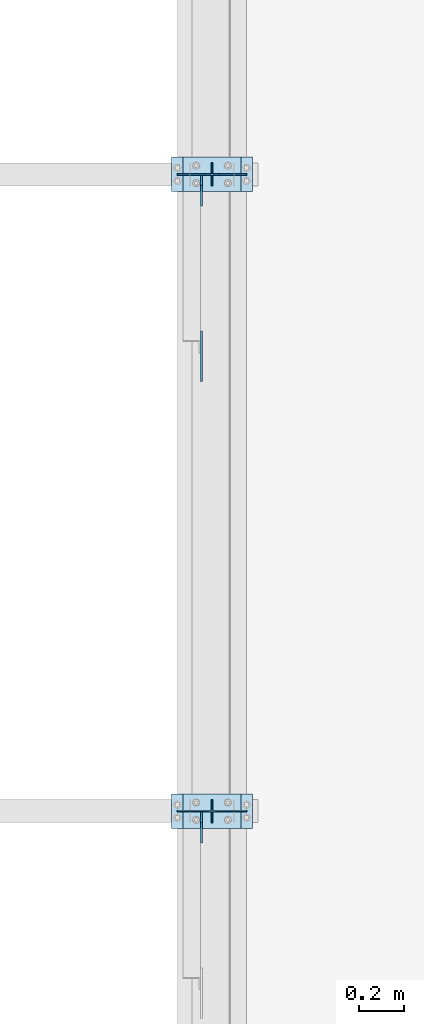
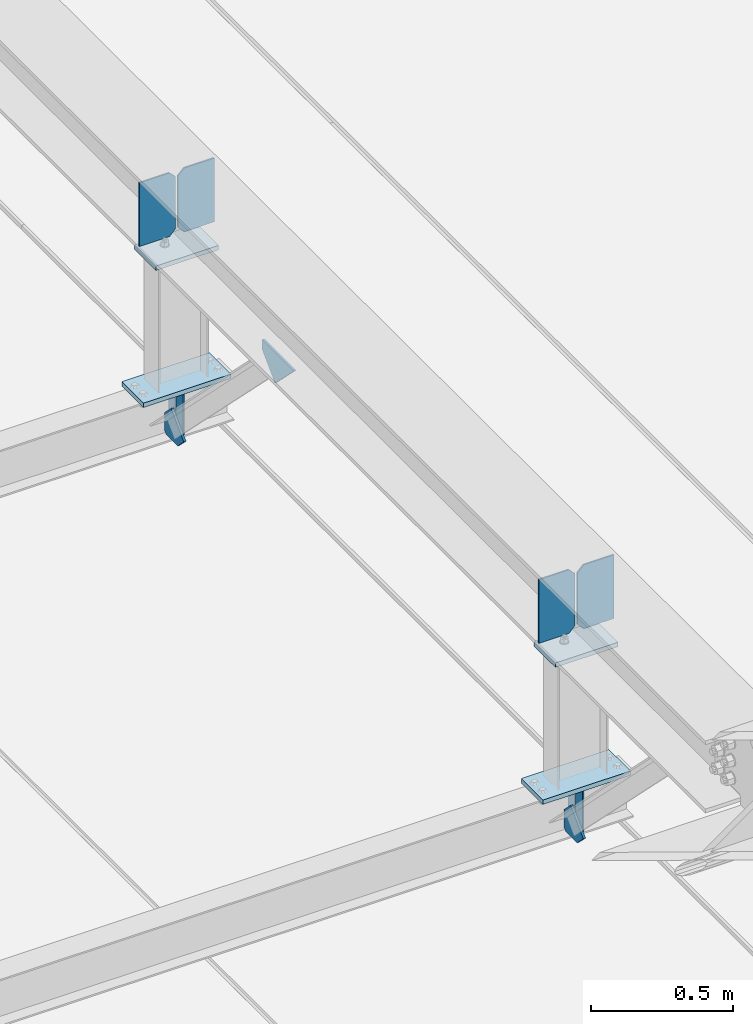
# One storey, part 3288 of 3843: 15 plates, 5 elements without a shape of their own.
"""IFC2X3 building model written with IfcOpenShell, lengths in millimetres."""

import ifcopenshell
import ifcopenshell.guid

model = None  # the IFC model being written
_history = None  # IfcOwnerHistory: only IFC2X3 demands one
_inside = {}  # id of a spatial element -> (the spatial element, [elements in it])
_under = {}  # id of a project, library or spatial element -> (it, [spatial elements below it])
_declared = {}  # id of a project -> (the project, [libraries it declares])
_typed = {}  # id of a type object -> (the type object, [elements of that type])
_made_of = {}  # id of a material, layer set ... -> (it, [elements and type objects made of it])


def new_model(schema):
    """Start an empty IFC model of exactly this schema.

    Asked for "IFC4X3", IfcOpenShell would pick the latest addendum, in which some entities
    have other attributes; the version numbers below select the first issue.
    IFC2X3 requires an IfcOwnerHistory on every rooted entity: one is made here for all.
    """
    global model, _history
    if schema == "IFC4X3":
        model = ifcopenshell.file(schema_version=(4, 3, 0, 0))
    else:
        model = ifcopenshell.file(schema=schema)
    _inside.clear()
    _under.clear()
    _declared.clear()
    _typed.clear()
    _made_of.clear()
    _history = None
    if model.schema == "IFC2X3":
        org = make("IfcOrganization", Name="unknown")
        user = make(
            "IfcPersonAndOrganization",
            ThePerson=make("IfcPerson", FamilyName="unknown"),
            TheOrganization=org,
        )
        app = make(
            "IfcApplication",
            ApplicationDeveloper=org,
            Version="unknown",
            ApplicationFullName="unknown",
            ApplicationIdentifier="unknown",
        )
        _history = make(
            "IfcOwnerHistory",
            OwningUser=user,
            OwningApplication=app,
            ChangeAction="ADDED",
            CreationDate=0,
        )
    return model


def make(cls, **values):
    """One entity of the class cls with the attributes given. An attribute that is None is left unset."""
    return model.create_entity(
        cls, **{name: value for name, value in values.items() if value is not None}
    )


def rooted(cls, **values):
    """An entity with a GlobalId (a new one), such as an element, a storey or a relation."""
    return make(cls, GlobalId=ifcopenshell.guid.new(), OwnerHistory=_history, **values)


def si_unit(unit_type, name, prefix=None):
    """IfcSIUnit, for example si_unit("LENGTHUNIT", "METRE", prefix="MILLI")."""
    return make("IfcSIUnit", UnitType=unit_type, Prefix=prefix, Name=name)


def assignment(units):
    """IfcUnitAssignment: the units of a project."""
    return None if units is None else make("IfcUnitAssignment", Units=units)


def point(xyz):
    """IfcCartesianPoint."""
    return None if xyz is None else make("IfcCartesianPoint", Coordinates=xyz)


def direction(xyz):
    """IfcDirection."""
    return None if xyz is None else make("IfcDirection", DirectionRatios=xyz)


def frame(location, z_axis=None, x_axis=None):
    """IfcAxis2Placement3D, a coordinate frame: its origin and axes. An axis left out is left unset."""
    return make(
        "IfcAxis2Placement3D",
        Location=point(location),
        Axis=direction(z_axis),
        RefDirection=direction(x_axis),
    )


def origin_with_axes():
    """The frame at (0, 0, 0) with the z axis (0, 0, 1) and the x axis (1, 0, 0) written out."""
    return frame((0.0, 0.0, 0.0), z_axis=(0.0, 0.0, 1.0), x_axis=(1.0, 0.0, 0.0))


def place(relative_to, where):
    """IfcLocalPlacement: puts the frame where relative to a parent placement (None: the world)."""
    return make(
        "IfcLocalPlacement", PlacementRelTo=relative_to, RelativePlacement=where
    )


def context(
    kind, dimensions, precision=None, world=None, true_north=None, identifier=None
):
    """IfcGeometricRepresentationContext, for example the 3D "Model" context."""
    return make(
        "IfcGeometricRepresentationContext",
        ContextIdentifier=identifier,
        ContextType=kind,
        CoordinateSpaceDimension=dimensions,
        Precision=precision,
        WorldCoordinateSystem=world,
        TrueNorth=true_north,
    )


def subcontext(parent, identifier, kind, view, scale=None):
    """IfcGeometricRepresentationSubContext, for example "Body" below "Model"."""
    return make(
        "IfcGeometricRepresentationSubContext",
        ContextIdentifier=identifier,
        ContextType=kind,
        ParentContext=parent,
        TargetScale=scale,
        TargetView=view,
    )


def project(units=None, contexts=None):
    """IfcProject with its units and contexts."""
    return rooted(
        "IfcProject",
        Name="project",
        RepresentationContexts=contexts,
        UnitsInContext=assignment(units),
    )


def spatial(cls, under=None, at=None, **own):
    """A site, building, storey or space (cls), placed at a placement, below another one or the project."""
    s = rooted(cls, ObjectPlacement=at, **own)
    if under is not None:
        _under.setdefault(under.id(), (under, []))[1].append(s)
    return s


def faces_of(points, faces, orient=None, outer=None):
    """IfcFace entities. A face is a list of loops; a loop is a list of indices into points, from 0.

    orient and outer hold one flag for each loop. By default every Orientation is true, the
    first loop of a face is its IfcFaceOuterBound and the others are IfcFaceBound.
    """
    made = []
    for i, loops in enumerate(faces):
        bounds = []
        for j, loop in enumerate(loops):
            is_outer = j == 0 if outer is None else outer[i][j]
            bounds.append(
                make(
                    "IfcFaceOuterBound" if is_outer else "IfcFaceBound",
                    Bound=make("IfcPolyLoop", Polygon=[points[k] for k in loop]),
                    Orientation=True if orient is None else orient[i][j],
                )
            )
        made.append(make("IfcFace", Bounds=bounds))
    return made


def faceted_brep(points, faces, orient=None, outer=None, voids=None):
    """IfcFacetedBrep: a solid bounded by flat faces; with voids (closed shells), ...WithVoids."""
    shared = [point(p) for p in points]
    hull = make("IfcClosedShell", CfsFaces=faces_of(shared, faces, orient, outer))
    if voids is None:
        return make("IfcFacetedBrep", Outer=hull)
    return make(
        "IfcFacetedBrepWithVoids",
        Outer=hull,
        Voids=[
            make(cls, CfsFaces=faces_of(shared, fs, o, b)) for cls, fs, o, b in voids
        ],
    )


def shape(context_of_items, identifier, shape_type, items):
    """IfcShapeRepresentation: the items that make up one representation, for example the "Body"."""
    return make(
        "IfcShapeRepresentation",
        ContextOfItems=context_of_items,
        RepresentationIdentifier=identifier,
        RepresentationType=shape_type,
        Items=items,
    )


def material(Name=None, Category=None):
    """IfcMaterial."""
    return make("IfcMaterial", Name=Name, Category=Category)


def made_of(thing, what):
    """Note that an element or type object is made of a material, layer set ...; save() writes the relation."""
    if what is not None:
        _made_of.setdefault(what.id(), (what, []))[1].append(thing)
    return thing


def type_object(cls, material=None, **own):
    """A type object (cls), such as IfcWallType, which elements share."""
    return made_of(rooted(cls, **own), material)


def element(
    cls,
    number,
    at=None,
    inside=None,
    cuts=None,
    type_object=None,
    material=None,
    context=None,
    identifier="Body",
    shape_type=None,
    held_by="IfcProductDefinitionShape",
    body=None,
    shapes=None,
    **own,
):
    """One element of the class cls, such as IfcWall. Its Tag is "e" and its number.

    at: its placement. inside: the storey or other place that contains it. cuts: it is an
    opening in that element (IfcRelVoidsElement). A single representation is given by context,
    identifier, shape_type and body (its items); several are given by shapes. held_by: the class
    of the entity that holds the representations. save() writes the other relations.
    """
    e = rooted(cls, Tag="e%d" % number, ObjectPlacement=at, **own)
    if body is not None:
        shapes = [shape(context, identifier, shape_type, body)]
    if shapes is not None:
        e.Representation = make(held_by, Representations=shapes)
    if inside is not None:
        _inside.setdefault(inside.id(), (inside, []))[1].append(e)
    if cuts is not None:
        rooted(
            "IfcRelVoidsElement", RelatingBuildingElement=cuts, RelatedOpeningElement=e
        )
    if type_object is not None:
        _typed.setdefault(type_object.id(), (type_object, []))[1].append(e)
    return made_of(e, material)


def aggregate(whole, parts):
    """IfcRelAggregates: a whole, such as a stair, and the parts it consists of."""
    return rooted("IfcRelAggregates", RelatingObject=whole, RelatedObjects=parts)


def save(model, path):
    """Write the relations noted so far, then the file.

    IfcRelAggregates (storeys below a building ...), IfcRelContainedInSpatialStructure (elements
    in a storey), IfcRelDefinesByType, IfcRelAssociatesMaterial and IfcRelDeclares: one each for
    every whole, place, type object, material and project.
    """
    for whole, parts in _under.values():
        aggregate(whole, parts)
    for where, things in _inside.values():
        rooted(
            "IfcRelContainedInSpatialStructure",
            RelatedElements=things,
            RelatingStructure=where,
        )
    for kind, things in _typed.values():
        rooted("IfcRelDefinesByType", RelatedObjects=things, RelatingType=kind)
    for what, things in _made_of.values():
        rooted("IfcRelAssociatesMaterial", RelatedObjects=things, RelatingMaterial=what)
    for by, libraries in _declared.values():
        rooted("IfcRelDeclares", RelatingContext=by, RelatedDefinitions=libraries)
    model.write(path)


model = new_model("IFC2X3")

# Units and contexts
model_context = context("Model", 3, precision=1e-05, world=origin_with_axes())
body_context = subcontext(model_context, "Body", "Model", "MODEL_VIEW")
ifc_project = project(units=[si_unit("LENGTHUNIT", "METRE", prefix="MILLI"), si_unit("AREAUNIT", "SQUARE_METRE"), si_unit("VOLUMEUNIT", "CUBIC_METRE"), si_unit("MASSUNIT", "GRAM", prefix="KILO"), si_unit("TIMEUNIT", "SECOND"), si_unit("PLANEANGLEUNIT", "RADIAN"), si_unit("SOLIDANGLEUNIT", "STERADIAN"), si_unit("THERMODYNAMICTEMPERATUREUNIT", "DEGREE_CELSIUS"), si_unit("LUMINOUSINTENSITYUNIT", "LUMEN")], contexts=[model_context])

# Site, building, storey
site_placement = place(None, origin_with_axes())
site = spatial("IfcSite", under=ifc_project, at=site_placement, CompositionType="ELEMENT")
building_placement = place(site_placement, origin_with_axes())
building = spatial("IfcBuilding", under=site, at=building_placement, Name="Undefined", CompositionType="ELEMENT")
storey_placement = place(building_placement, origin_with_axes())
storey = spatial("IfcBuildingStorey", under=building, at=storey_placement, Name="Undefined", CompositionType="ELEMENT", Elevation=0.0)

# Assembly, plates
assembly_1_placement = place(storey_placement, origin_with_axes())
assembly_1 = element("IfcElementAssembly", 1, at=assembly_1_placement, inside=storey, Name="BEAM", AssemblyPlace="NOTDEFINED", PredefinedType="RIGID_FRAME")
ifc_material = material(Name="STEEL/A572-50")
plate_type_1 = type_object("IfcPlateType", PredefinedType="NOTDEFINED")
plate_1_placement = place(assembly_1_placement, frame((42062.4, 60236.1, 41495.6625), z_axis=(0.0, 0.0, -1.0), x_axis=(0.0, 1.0, 0.0)))
plate_1 = element("IfcPlate", 2, at=plate_1_placement, type_object=plate_type_1, material=ifc_material, Name="PLATE", context=body_context, shape_type="Brep", body=[
    faceted_brep([(0.0, -3.17499999999927, 0.0), (0.0, -3.17500000000291, 187.324999999997), (0.0, 3.17500000000291, 187.324999999997), (0.0, 3.17499999999927, 0.0), (34.9250001907349, -3.17500000000291, 187.324999999997), (34.9250001907349, 3.17500000000291, 187.324999999997), (47.625, -3.17500000000291, 174.625000190732), (47.625, 3.17500000000291, 174.625000190732), (47.625, -3.17499999999927, 12.6999998092651), (47.625, 3.17499999999927, 12.6999998092651), (34.9250001907349, -3.17499999999927, 0.0), (34.9250001907349, 3.17499999999927, 0.0)], [[[0, 1, 2, 3]], [[1, 4, 5, 2]], [[4, 6, 7, 5]], [[6, 8, 9, 7]], [[8, 10, 11, 9]], [[10, 0, 3, 11]], [[5, 7, 9, 11, 3, 2]], [[10, 8, 6, 4, 1, 0]]]),
])
plate_2_placement = place(assembly_1_placement, frame((42062.4, 60337.7, 41495.6625), z_axis=(0.0, 0.0, -1.0), x_axis=(0.0, -1.0, 0.0)))
plate_2 = element("IfcPlate", 3, at=plate_2_placement, type_object=plate_type_1, material=ifc_material, Name="PLATE", context=body_context, shape_type="Brep", body=[
    faceted_brep([(0.0, -3.17499999999927, 0.0), (0.0, -3.17500000000291, 187.324999999997), (0.0, 3.17500000000291, 187.324999999997), (0.0, 3.17499999999927, 0.0), (34.9250001907349, -3.17500000000291, 187.324999999997), (34.9250001907349, 3.17500000000291, 187.324999999997), (47.625, -3.17500000000291, 174.625000190732), (47.625, 3.17500000000291, 174.625000190732), (47.625, -3.17499999999927, 12.6999998092651), (47.625, 3.17499999999927, 12.6999998092651), (34.9250001907349, -3.17499999999927, 0.0), (34.9250001907349, 3.17499999999927, 0.0)], [[[0, 1, 2, 3]], [[1, 4, 5, 2]], [[4, 6, 7, 5]], [[6, 8, 9, 7]], [[8, 10, 11, 9]], [[10, 0, 3, 11]], [[5, 7, 9, 11, 3, 2]], [[10, 8, 6, 4, 1, 0]]]),
])

assembly_2_placement = place(storey_placement, origin_with_axes())
assembly_2 = element("IfcElementAssembly", 4, at=assembly_2_placement, inside=storey, Name="BEAM", AssemblyPlace="NOTDEFINED", PredefinedType="RIGID_FRAME")
plate_3_placement = place(assembly_2_placement, frame((42062.4, 63042.8, 41495.6625), z_axis=(0.0, 0.0, -1.0), x_axis=(0.0, 1.0, 0.0)))
plate_3 = element("IfcPlate", 5, at=plate_3_placement, type_object=plate_type_1, material=ifc_material, Name="PLATE", context=body_context, shape_type="Brep", body=[
    faceted_brep([(0.0, -3.17499999999927, 0.0), (0.0, -3.17500000000291, 187.324999999997), (0.0, 3.17500000000291, 187.324999999997), (0.0, 3.17499999999927, 0.0), (34.9250001907349, -3.17500000000291, 187.324999999997), (34.9250001907349, 3.17500000000291, 187.324999999997), (47.625, -3.17500000000291, 174.625000190732), (47.625, 3.17500000000291, 174.625000190732), (47.625, -3.17499999999927, 12.6999998092651), (47.625, 3.17499999999927, 12.6999998092651), (34.9250001907349, -3.17499999999927, 0.0), (34.9250001907349, 3.17499999999927, 0.0)], [[[0, 1, 2, 3]], [[1, 4, 5, 2]], [[4, 6, 7, 5]], [[6, 8, 9, 7]], [[8, 10, 11, 9]], [[10, 0, 3, 11]], [[5, 7, 9, 11, 3, 2]], [[10, 8, 6, 4, 1, 0]]]),
])
plate_4_placement = place(assembly_2_placement, frame((42062.4, 63144.4, 41495.6625), z_axis=(0.0, 0.0, -1.0), x_axis=(0.0, -1.0, 0.0)))
plate_4 = element("IfcPlate", 6, at=plate_4_placement, type_object=plate_type_1, material=ifc_material, Name="PLATE", context=body_context, shape_type="Brep", body=[
    faceted_brep([(0.0, -3.17499999999927, 0.0), (0.0, -3.17500000000291, 187.324999999997), (0.0, 3.17500000000291, 187.324999999997), (0.0, 3.17499999999927, 0.0), (34.9250001907349, -3.17500000000291, 187.324999999997), (34.9250001907349, 3.17500000000291, 187.324999999997), (47.625, -3.17500000000291, 174.625000190732), (47.625, 3.17500000000291, 174.625000190732), (47.625, -3.17499999999927, 12.6999998092651), (47.625, 3.17499999999927, 12.6999998092651), (34.9250001907349, -3.17499999999927, 0.0), (34.9250001907349, 3.17499999999927, 0.0)], [[[0, 1, 2, 3]], [[1, 4, 5, 2]], [[4, 6, 7, 5]], [[6, 8, 9, 7]], [[8, 10, 11, 9]], [[10, 0, 3, 11]], [[5, 7, 9, 11, 3, 2]], [[10, 8, 6, 4, 1, 0]]]),
])

# Assembly, plate
assembly_3_placement = place(storey_placement, origin_with_axes())
assembly_3 = element("IfcElementAssembly", 7, at=assembly_3_placement, inside=storey, Name="POST", AssemblyPlace="NOTDEFINED", PredefinedType="RIGID_FRAME")
plate_type_2 = type_object("IfcPlateType", PredefinedType="NOTDEFINED")
plate_5_placement = place(assembly_3_placement, frame((41935.3999968995, 60363.0992628227, 42083.0375000287), z_axis=(0.0, -0.999999997006942, 7.73699999990641e-05), x_axis=(1.0, 0.0, 0.0)))
plate_5 = element("IfcPlate", 8, at=plate_5_placement, type_object=plate_type_2, material=ifc_material, Name="PLATE", context=body_context, shape_type="Brep", body=[
    faceted_brep([(0.0, -9.52500000000146, 0.0), (0.0, -9.5249999999287, 152.40000000162), (0.0, 9.52500000002328, 152.40000000162), (0.0, 9.52500000000146, 0.0), (254.0, -9.5249999999287, 152.40000000162), (254.0, 9.52500000002328, 152.40000000162), (253.999999999998, -9.52500000000146, 0.0), (253.999999999998, 9.52500000000146, 0.0)], [[[0, 1, 2, 3]], [[1, 4, 5, 2]], [[4, 6, 7, 5]], [[6, 0, 3, 7]], [[5, 7, 3, 2]], [[6, 4, 1, 0]]]),
])

assembly_4_placement = place(storey_placement, origin_with_axes())
assembly_4 = element("IfcElementAssembly", 9, at=assembly_4_placement, inside=storey, Name="POST", AssemblyPlace="NOTDEFINED", PredefinedType="RIGID_FRAME")
plate_6_placement = place(assembly_4_placement, frame((41935.3999975205, 63169.7992628227, 42083.0375000287), z_axis=(0.0, -0.999999997006942, 7.73699999990641e-05), x_axis=(1.0, 0.0, 0.0)))
plate_6 = element("IfcPlate", 10, at=plate_6_placement, type_object=plate_type_2, material=ifc_material, Name="PLATE", context=body_context, shape_type="Brep", body=[
    faceted_brep([(0.0, -9.52500000000146, 0.0), (0.0, -9.5249999999287, 152.40000000162), (0.0, 9.52500000002328, 152.40000000162), (0.0, 9.52500000000146, 0.0), (254.0, -9.5249999999287, 152.40000000162), (254.0, 9.52500000002328, 152.40000000162), (253.999999999998, -9.52500000000146, 0.0), (253.999999999998, 9.52500000000146, 0.0)], [[[0, 1, 2, 3]], [[1, 4, 5, 2]], [[4, 6, 7, 5]], [[6, 0, 3, 7]], [[5, 7, 3, 2]], [[6, 4, 1, 0]]]),
])

# Plate
plate_7_placement = place(assembly_3_placement, frame((42240.2, 60210.7, 41513.125), z_axis=(-1.0, 0.0, 0.0), x_axis=(0.0, 1.0, 0.0)))
plate_7 = element("IfcPlate", 11, at=plate_7_placement, type_object=plate_type_2, material=ifc_material, Name="PLATE", context=body_context, shape_type="Brep", body=[
    faceted_brep([(0.0, -9.52500000000146, 0.0), (0.0, -9.52500000000146, 355.599999999999), (0.0, 9.52500000000146, 355.599999999999), (0.0, 9.52500000000146, 0.0), (152.399999999994, -9.52500000000146, 355.599999999999), (152.399999999994, 9.52500000000146, 355.599999999999), (152.400000000001, -9.52500000000146, 0.0), (152.400000000001, 9.52500000000146, 0.0)], [[[0, 1, 2, 3]], [[1, 4, 5, 2]], [[4, 6, 7, 5]], [[6, 0, 3, 7]], [[5, 7, 3, 2]], [[6, 4, 1, 0]]]),
])

aggregate(assembly_3, [plate_5, plate_7])

plate_8_placement = place(assembly_4_placement, frame((42240.2, 63017.4, 41513.125), z_axis=(-1.0, 0.0, 0.0), x_axis=(0.0, 1.0, 0.0)))
plate_8 = element("IfcPlate", 12, at=plate_8_placement, type_object=plate_type_2, material=ifc_material, Name="PLATE", context=body_context, shape_type="Brep", body=[
    faceted_brep([(0.0, -9.52500000000146, 0.0), (0.0, -9.52500000000146, 355.599999999999), (0.0, 9.52500000000146, 355.599999999999), (0.0, 9.52500000000146, 0.0), (152.399999999994, -9.52500000000146, 355.599999999999), (152.399999999994, 9.52500000000146, 355.599999999999), (152.400000000001, -9.52500000000146, 0.0), (152.400000000001, 9.52500000000146, 0.0)], [[[0, 1, 2, 3]], [[1, 4, 5, 2]], [[4, 6, 7, 5]], [[6, 0, 3, 7]], [[5, 7, 3, 2]], [[6, 4, 1, 0]]]),
])

aggregate(assembly_4, [plate_6, plate_8])

# Assembly, plate
assembly_5_placement = place(storey_placement, origin_with_axes())
assembly_5 = element("IfcElementAssembly", 13, at=assembly_5_placement, inside=storey, Name="BEAM", AssemblyPlace="NOTDEFINED", PredefinedType="RIGID_FRAME")
plate_type_3 = type_object("IfcPlateType", PredefinedType="NOTDEFINED")
plate_9_placement = place(assembly_5_placement, frame((42016.3625, 62180.5605139139, 42123.5434634989), z_axis=(0.0, 0.707106781186548, 0.707106781186548), x_axis=(5.70000238222118e-08, 0.707106781186546, -0.707106781186546)))
plate_9 = element("IfcPlate", 14, at=plate_9_placement, type_object=plate_type_3, material=ifc_material, Name="PLATE", context=body_context, shape_type="Brep", body=[
    faceted_brep([(0.0, -4.76249999999709, 0.0), (157.726597423803, -4.76249999999709, 157.726601438866), (157.726597423803, 4.76249999999709, 157.726601438866), (0.0, 4.76249999999709, 0.0), (188.387110059113, -4.76249999999709, 127.066089584019), (188.387110059113, 4.76249999999709, 127.066089584019), (188.387111679331, -4.76249999999709, 1.09139364212751e-10), (188.387111679331, 4.76249999999709, 1.09139364212751e-10)], [[[0, 1, 2, 3]], [[1, 4, 5, 2]], [[4, 6, 7, 5]], [[6, 0, 3, 7]], [[5, 7, 3, 2]], [[6, 4, 1, 0]]]),
])

# Plate
plate_type_4 = type_object("IfcPlateType", PredefinedType="NOTDEFINED")
plate_10_placement = place(assembly_1_placement, frame((42016.3625, 60283.7250000139, 41306.750000025), z_axis=(0.0, -1.0, 0.0), x_axis=(0.0, 0.0, 1.0)))
plate_10 = element("IfcPlate", 15, at=plate_10_placement, type_object=plate_type_4, material=ifc_material, Name="PLATE", context=body_context, shape_type="Brep", body=[
    faceted_brep([(0.0, -4.76250000000073, 12.6999998092651), (4.450703272596e-08, -4.76249999999709, 93.0710244828806), (4.450703272596e-08, 4.76249999999709, 93.0710244828806), (0.0, 4.76250000000073, 12.6999998092651), (43.3137807601452, -4.76249999999709, 136.384805065652), (43.3137807601452, 4.76249999999709, 136.384805065652), (133.209805202001, -4.76249999999709, 46.4887805392646), (133.209805202001, 4.76249999999709, 46.4887805392646), (86.7210245267561, -4.76249999999709, 0.0), (86.7210245267561, 4.76249999999709, 0.0), (12.6999998092651, -4.76250000000073, 0.0), (12.6999998092651, 4.76250000000073, 0.0)], [[[0, 1, 2, 3]], [[1, 4, 5, 2]], [[4, 6, 7, 5]], [[6, 8, 9, 7]], [[8, 10, 11, 9]], [[10, 0, 3, 11]], [[5, 7, 9, 11, 3, 2]], [[10, 8, 6, 4, 1, 0]]]),
])

aggregate(assembly_1, [plate_10, plate_1, plate_2])

plate_11_placement = place(assembly_2_placement, frame((42016.3625, 63090.4250000139, 41306.750000025), z_axis=(0.0, -1.0, 0.0), x_axis=(0.0, 0.0, 1.0)))
plate_11 = element("IfcPlate", 16, at=plate_11_placement, type_object=plate_type_4, material=ifc_material, Name="PLATE", context=body_context, shape_type="Brep", body=[
    faceted_brep([(0.0, -4.76250000000073, 12.6999998092651), (4.450703272596e-08, -4.76249999999709, 93.0710244828806), (4.450703272596e-08, 4.76249999999709, 93.0710244828806), (0.0, 4.76250000000073, 12.6999998092651), (43.3137807601452, -4.76249999999709, 136.384805065652), (43.3137807601452, 4.76249999999709, 136.384805065652), (133.209805202001, -4.76249999999709, 46.4887805392646), (133.209805202001, 4.76249999999709, 46.4887805392646), (86.7210245267561, -4.76249999999709, 0.0), (86.7210245267561, 4.76249999999709, 0.0), (12.6999998092651, -4.76250000000073, 0.0), (12.6999998092651, 4.76250000000073, 0.0)], [[[0, 1, 2, 3]], [[1, 4, 5, 2]], [[4, 6, 7, 5]], [[6, 8, 9, 7]], [[8, 10, 11, 9]], [[10, 0, 3, 11]], [[5, 7, 9, 11, 3, 2]], [[10, 8, 6, 4, 1, 0]]]),
])

aggregate(assembly_2, [plate_11, plate_3, plate_4])

plate_type_5 = type_object("IfcPlateType", PredefinedType="NOTDEFINED")
plate_12_placement = place(assembly_5_placement, frame((42214.8, 60286.9224769521, 42414.2094304047), z_axis=(0.0, -7.73699999990641e-05, -0.999999997006942), x_axis=(-1.0, 0.0, 0.0)))
plate_12 = element("IfcPlate", 17, at=plate_12_placement, type_object=plate_type_5, material=ifc_material, Name="PLATE", context=body_context, shape_type="Brep", body=[
    faceted_brep([(0.0, -3.17499999999927, 0.0), (0.0, -3.17500000007567, 273.049999997937), (0.0, 3.17499999993743, 273.049999997937), (0.0, 3.17499999999927, 0.0), (122.237500389827, -3.17500000007567, 273.049999997937), (122.237500389827, 3.17499999993743, 273.049999997937), (147.637500008357, -3.17500000006476, 247.650000379464), (147.637500008357, 3.17499999994106, 247.650000379464), (147.637500008357, -3.17500000001382, 25.3999996184648), (147.637500008357, 3.17499999999927, 25.3999996184648), (122.237500389827, -3.17500000000291, 0.0), (122.237500389827, 3.17500000000291, -7.27595761418343e-12)], [[[0, 1, 2, 3]], [[1, 4, 5, 2]], [[4, 6, 7, 5]], [[6, 8, 9, 7]], [[8, 10, 11, 9]], [[10, 0, 3, 11]], [[5, 7, 9, 11, 3, 2]], [[10, 8, 6, 4, 1, 0]]]),
])

plate_13_placement = place(assembly_5_placement, frame((41910.0, 60286.9224769521, 42414.2094304047), z_axis=(0.0, -7.73699999990641e-05, -0.999999997006942), x_axis=(1.0, 0.0, 0.0)))
plate_13 = element("IfcPlate", 18, at=plate_13_placement, type_object=plate_type_5, material=ifc_material, Name="PLATE", context=body_context, shape_type="Brep", body=[
    faceted_brep([(0.0, -3.17499999999927, 0.0), (0.0, -3.17500000007567, 273.049999997937), (0.0, 3.17499999993743, 273.049999997937), (0.0, 3.17499999999927, 0.0), (122.237500389827, -3.17500000007567, 273.049999997937), (122.237500389827, 3.17499999993743, 273.049999997937), (147.637500008357, -3.17500000006476, 247.650000379464), (147.637500008357, 3.17499999994106, 247.650000379464), (147.637500008357, -3.17500000001382, 25.3999996184648), (147.637500008357, 3.17499999999927, 25.3999996184648), (122.237500389827, -3.17500000000291, 0.0), (122.237500389827, 3.17500000000291, -7.27595761418343e-12)], [[[0, 1, 2, 3]], [[1, 4, 5, 2]], [[4, 6, 7, 5]], [[6, 8, 9, 7]], [[8, 10, 11, 9]], [[10, 0, 3, 11]], [[5, 7, 9, 11, 3, 2]], [[10, 8, 6, 4, 1, 0]]]),
])

plate_14_placement = place(assembly_5_placement, frame((42214.8, 63093.6224769521, 42413.992276025), z_axis=(0.0, -7.73699999990641e-05, -0.999999997006942), x_axis=(-1.0, 0.0, 0.0)))
plate_14 = element("IfcPlate", 19, at=plate_14_placement, type_object=plate_type_5, material=ifc_material, Name="PLATE", context=body_context, shape_type="Brep", body=[
    faceted_brep([(0.0, -3.17499999999927, 0.0), (0.0, -3.17500000007567, 273.049999997937), (0.0, 3.17499999993743, 273.049999997937), (0.0, 3.17499999999927, 0.0), (122.237500389827, -3.17500000007567, 273.049999997937), (122.237500389827, 3.17499999993743, 273.049999997937), (147.637500008357, -3.17500000006476, 247.650000379464), (147.637500008357, 3.17499999994106, 247.650000379464), (147.637500008357, -3.17500000001382, 25.3999996184648), (147.637500008357, 3.17499999999927, 25.3999996184648), (122.237500389827, -3.17500000000291, 0.0), (122.237500389827, 3.17500000000291, -7.27595761418343e-12)], [[[0, 1, 2, 3]], [[1, 4, 5, 2]], [[4, 6, 7, 5]], [[6, 8, 9, 7]], [[8, 10, 11, 9]], [[10, 0, 3, 11]], [[5, 7, 9, 11, 3, 2]], [[10, 8, 6, 4, 1, 0]]]),
])

plate_15_placement = place(assembly_5_placement, frame((41910.0, 63093.6224769521, 42413.992276025), z_axis=(0.0, -7.73699999990641e-05, -0.999999997006942), x_axis=(1.0, 0.0, 0.0)))
plate_15 = element("IfcPlate", 20, at=plate_15_placement, type_object=plate_type_5, material=ifc_material, Name="PLATE", context=body_context, shape_type="Brep", body=[
    faceted_brep([(0.0, -3.17499999999927, 0.0), (0.0, -3.17500000007567, 273.049999997937), (0.0, 3.17499999993743, 273.049999997937), (0.0, 3.17499999999927, 0.0), (122.237500389827, -3.17500000007567, 273.049999997937), (122.237500389827, 3.17499999993743, 273.049999997937), (147.637500008357, -3.17500000006476, 247.650000379464), (147.637500008357, 3.17499999994106, 247.650000379464), (147.637500008357, -3.17500000001382, 25.3999996184648), (147.637500008357, 3.17499999999927, 25.3999996184648), (122.237500389827, -3.17500000000291, 0.0), (122.237500389827, 3.17500000000291, -7.27595761418343e-12)], [[[0, 1, 2, 3]], [[1, 4, 5, 2]], [[4, 6, 7, 5]], [[6, 8, 9, 7]], [[8, 10, 11, 9]], [[10, 0, 3, 11]], [[5, 7, 9, 11, 3, 2]], [[10, 8, 6, 4, 1, 0]]]),
])

aggregate(assembly_5, [plate_12, plate_13, plate_14, plate_15, plate_9])

save(model, "model.ifc")
